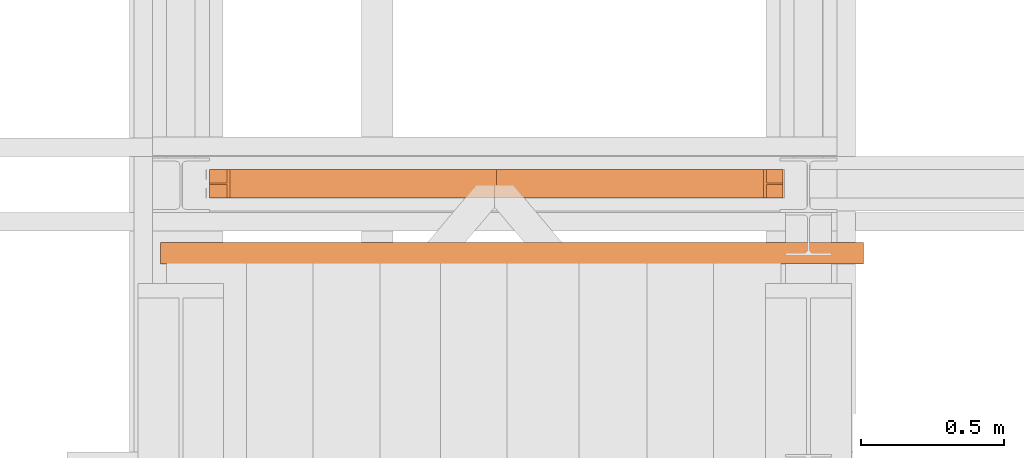
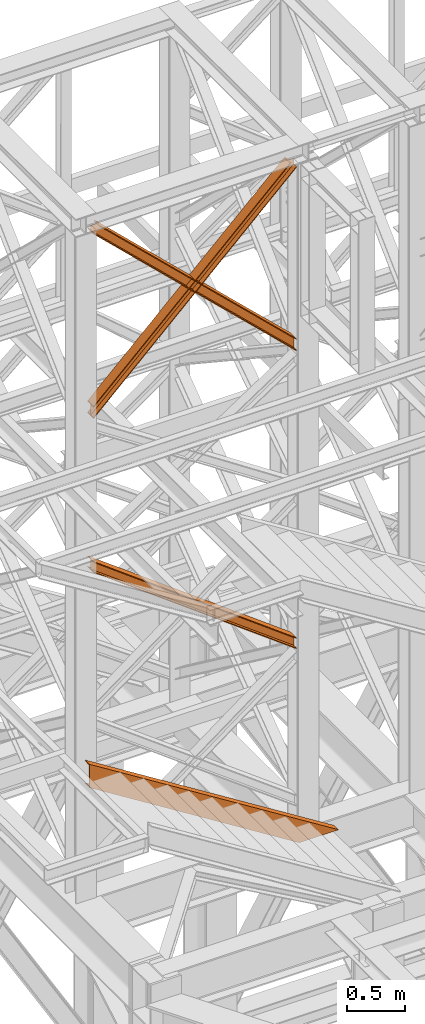
# One storey, part 89 of 208: 4 proxies.
"""IFC2X3 building model written with IfcOpenShell, lengths in millimetres."""

from ifc_helpers import new_model, entity, si_unit, converted_unit, frame, origin, origin_with_axes, place, context, subcontext, project, spatial, faceted_brep, element, save


model = new_model("IFC2X3")

# Units and contexts
model_context = context("Model", 3, precision=1e-05, world=origin())
plan_context = context("Plan", 3, precision=1e-05, world=origin())
body_context = subcontext(model_context, "Body", "Model", "MODEL_VIEW")
ifc_project = project(units=[si_unit("LENGTHUNIT", "METRE", prefix="MILLI"), converted_unit("PLANEANGLEUNIT", "DEGREE", entity("IfcPlaneAngleMeasure", 0.0174532925199433), si_unit("PLANEANGLEUNIT", "RADIAN"), dimensions=[0, 0, 0, 0, 0, 0, 0]), si_unit("AREAUNIT", "SQUARE_METRE"), si_unit("VOLUMEUNIT", "CUBIC_METRE")], contexts=[model_context, plan_context])

# Building, storey
building_placement = place(None, origin())
building = spatial("IfcBuilding", under=ifc_project, at=building_placement, CompositionType="COMPLEX")
storey_placement = place(building_placement, origin_with_axes())
storey = spatial("IfcBuildingStorey", under=building, at=storey_placement, Name="Geschoss", CompositionType="ELEMENT")

# Proxies
proxy_1_placement = place(storey_placement, frame((-3206.582751348882, -16012.93371125112, 7147.394064575148), z_axis=(0.0, 0.0, 1.0), x_axis=(1.0, 0.0, 0.0)))
element("IfcBuildingElementProxy", 1, at=proxy_1_placement, inside=storey, context=body_context, shape_type="Brep", body=[
    faceted_brep([(0.01000000000021828, 100.0229386519495, 1501.524522111415), (2010.009987483026, 100.1855729074941, 0.02100513656296243), (2010.009987483026, 100.1844946360343, 9.82075546136366), (0.01000000000021828, 100.0218603804897, 1511.324272436212), (0.01000000000021828, 0.0229392575147358, 1501.513516974852), (2010.009987483026, 0.185573513057534, 0.01000000000021828), (2010.009987483026, 100.1855729074941, 0.02100513656296243), (0.01000000000021828, 100.0229386519495, 1501.524522111415), (0.01000000000067303, 0.02186098605307052, 1511.313267299649), (2010.009987483026, 0.1844952415976877, 9.809750324800916), (2010.009987483026, 0.185573513057534, 0.01000000000021828), (0.01000000000021828, 0.0229392575147358, 1501.513516974852), (0.01000000000021828, 47.52186069841082, 1511.318494739518), (2010.009987483026, 47.68449495395362, 9.814977764666764), (2010.009987483026, 0.1844952415976877, 9.809750324800916), (0.01000000000067303, 0.02186098605307052, 1511.313267299649), (0.01000000000067303, 47.51107798381236, 1609.315997987507), (2010.009987483026, 47.67371223935879, 107.8124810126556), (2010.009987483026, 47.68449495395362, 9.814977764666764), (0.01000000000021828, 47.52186069841082, 1511.318494739518), (0.01000000000067303, 0.01107827145824558, 1609.310770547641), (2010.009987483026, 0.1737125270010438, 107.8072535727861), (2010.009987483026, 47.67371223935879, 107.8124810126556), (0.01000000000067303, 47.51107798381236, 1609.315997987507), (0.01000000000067303, 0.00999999999839929, 1619.110520872438), (2010.009987483026, 0.1726342555430165, 117.6070038975868), (2010.009987483026, 0.1737125270010438, 107.8072535727861), (0.01000000000067303, 0.01107827145824558, 1609.310770547641), (0.01000000000021828, 100.0099993944332, 1619.121526009001), (2010.009987483026, 100.172633649976, 117.6180090341495), (2010.009987483026, 0.1726342555430165, 117.6070038975868), (0.01000000000067303, 0.00999999999839929, 1619.110520872438), (0.01000000000021828, 100.011077665893, 1609.321775684197), (2010.009987483026, 100.1737119214358, 107.8182587093452), (2010.009987483026, 100.172633649976, 117.6180090341495), (0.01000000000021828, 100.0099993944332, 1619.121526009001), (0.01000000000021828, 52.51107795353528, 1609.316548244331), (2010.009987483026, 52.67371220908171, 107.8130312694793), (2010.009987483026, 100.1737119214358, 107.8182587093452), (0.01000000000021828, 100.011077665893, 1609.321775684197), (0.01000000000067303, 52.52186066813192, 1511.319044996339), (2010.009987483026, 52.68449492367836, 9.815528021497812), (2010.009987483026, 52.67371220908171, 107.8130312694793), (0.01000000000021828, 52.51107795353528, 1609.316548244331), (0.01000000000021828, 100.0218603804897, 1511.324272436212), (2010.009987483026, 100.1844946360343, 9.82075546136366), (2010.009987483026, 52.68449492367836, 9.815528021497812), (0.01000000000067303, 52.52186066813192, 1511.319044996339), (2010.009987483026, 100.1855729074941, 0.02100513656296243), (2010.009987483026, 0.185573513057534, 0.01000000000021828), (2010.009987483026, 0.1844952415976877, 9.809750324800916), (2010.009987483026, 47.68449495395362, 9.814977764666764), (2010.009987483026, 47.67371223935879, 107.8124810126556), (2010.009987483026, 0.1737125270010438, 107.8072535727861), (2010.009987483026, 0.1726342555430165, 117.6070038975868), (2010.009987483026, 100.172633649976, 117.6180090341495), (2010.009987483026, 100.1737119214358, 107.8182587093452), (2010.009987483026, 52.67371220908171, 107.8130312694793), (2010.009987483026, 52.68449492367836, 9.815528021497812), (2010.009987483026, 100.1844946360343, 9.82075546136366), (0.01000000000021828, 100.0218603804897, 1511.324272436212), (0.01000000000067303, 52.52186066813192, 1511.319044996339), (0.01000000000021828, 52.51107795353528, 1609.316548244331), (0.01000000000021828, 100.011077665893, 1609.321775684197), (0.01000000000021828, 100.0099993944332, 1619.121526009001), (0.01000000000067303, 0.00999999999839929, 1619.110520872438), (0.01000000000067303, 0.01107827145824558, 1609.310770547641), (0.01000000000067303, 47.51107798381236, 1609.315997987507), (0.01000000000021828, 47.52186069841082, 1511.318494739518), (0.01000000000067303, 0.02186098605307052, 1511.313267299649), (0.01000000000021828, 0.0229392575147358, 1501.513516974852), (0.01000000000021828, 100.0229386519495, 1501.524522111415)], [[[0, 1, 2, 3]], [[4, 5, 6, 7]], [[8, 9, 10, 11]], [[12, 13, 14, 15]], [[16, 17, 18, 19]], [[20, 21, 22, 23]], [[24, 25, 26, 27]], [[28, 29, 30, 31]], [[32, 33, 34, 35]], [[36, 37, 38, 39]], [[40, 41, 42, 43]], [[44, 45, 46, 47]], [[48, 49, 50, 51, 52, 53, 54, 55, 56, 57, 58, 59]], [[60, 61, 62, 63, 64, 65, 66, 67, 68, 69, 70, 71]]], orient=[[False], [False], [False], [False], [False], [False], [False], [False], [False], [False], [False], [False], [False], [False]]),
])
proxy_2_placement = place(storey_placement, frame((-3206.582751348882, -16013.12009277258, 10257.71351554296), z_axis=(0.0, 0.0, 1.0), x_axis=(1.0, 0.0, 0.0)))
element("IfcBuildingElementProxy", 2, at=proxy_2_placement, inside=storey, context=body_context, shape_type="Brep", body=[
    faceted_brep([(0.009999999999763531, 100.0212045496901, 119.6472293306997), (1953.293711336966, 100.1463438185765, 1992.286543150845), (1941.949222048048, 100.1466350609662, 1992.286543150845), (0.01000000000021828, 100.0222231921616, 130.5233411127829), (0.01000000000021828, 100.0222231921616, 130.5233411127829), (1941.949222048048, 100.1466350609662, 1992.286543150845), (1941.937468339427, 0.1466348943758931, 1992.286543150842), (0.01000000000067303, 0.02222377857833635, 130.5346095510231), (0.01000000000067303, 0.02222377857833635, 130.5346095510231), (1941.937468339427, 0.1466348943758931, 1992.286543150842), (1953.281957628329, 0.1463436519825336, 1992.286543150842), (0.01000000000067303, 0.02120513611225761, 119.6584977689327), (0.01000000000067303, 0.02120513611225761, 119.6584977689327), (1953.281957628329, 0.1463436519825336, 1992.286543150842), (1953.287540639933, 47.64634373111403, 1992.286543150845), (0.01000000000067303, 47.52120485756132, 119.6531452607651), (0.01000000000067303, 47.52120485756132, 119.6531452607651), (1953.287540639933, 47.64634373111403, 1992.286543150845), (2010.009987483026, 47.64488761591929, 1992.286543150845), (2010.009987483026, 47.63979748861675, 1937.905972056111), (0.01000000000021828, 47.51101837541864, 10.89202766673589), (0.01000000000021828, 47.51101837541864, 10.89202766673589), (2010.009987483026, 47.63979748861675, 1937.905972056111), (2010.009987483026, 0.1397977671695116, 1937.911324564264), (0.01000000000067303, 0.011018653971405, 10.89738017488162), (0.01000000000067303, 0.011018653971405, 10.89738017488162), (2010.009987483026, 0.1397977671695116, 1937.911324564264), (2010.009987483026, 0.138779739916572, 1927.035210352397), (0.01000000000067303, 0.01000000000021828, 0.02126843821861257), (0.01000000000067303, 0.01000000000021828, 0.02126843821861257), (2010.009987483026, 0.138779739916572, 1927.035210352397), (2010.009987483026, 100.1387791534962, 1927.023941914182), (0.01000000000112777, 100.0099994135762, 0.01000000000021828), (0.01000000000112777, 100.0099994135762, 0.01000000000021828), (2010.009987483026, 100.1387791534962, 1927.023941914182), (2010.009987483026, 100.1397971807455, 1937.900056126053), (0.01000000000067303, 100.0110180675511, 10.88611173667414), (0.01000000000067303, 100.0110180675511, 10.88611173667414), (2010.009987483026, 100.1397971807455, 1937.900056126053), (2010.009987483026, 52.63979745929828, 1937.905408634202), (0.01000000000067303, 52.51101834609835, 10.89146424482351), (0.01000000000067303, 52.51101834609835, 10.89146424482351), (2010.009987483026, 52.63979745929828, 1937.905408634202), (2010.009993572537, 52.64488763917871, 1992.286543150845), (1953.288128325361, 52.64634373944318, 1992.286543150845), (0.01000000000021828, 52.52120482823921, 119.65258183886), (0.01000000000021828, 52.52120482823921, 119.65258183886), (1953.288128325361, 52.64634373944318, 1992.286543150845), (1953.293711336966, 100.1463438185765, 1992.286543150845), (0.009999999999763531, 100.0212045496901, 119.6472293306997), (1953.293711336966, 100.1463438185765, 1992.286543150845), (1953.288128325361, 52.64634373944318, 1992.286543150845), (2010.009993572537, 52.64488763917871, 1992.286543150845), (2010.009987483026, 47.64488761591929, 1992.286543150845), (1953.287540639933, 47.64634373111403, 1992.286543150845), (1953.281957628329, 0.1463436519825336, 1992.286543150842), (1941.937468339427, 0.1466348943758931, 1992.286543150842), (1941.949222048048, 100.1466350609662, 1992.286543150845), (2010.009987483026, 47.64488761591929, 1992.286543150845), (2010.009993572537, 52.64488763917871, 1992.286543150845), (2010.009987483026, 52.63979745929828, 1937.905408634202), (2010.009987483026, 100.1397971807455, 1937.900056126053), (2010.009987483026, 100.1387791534962, 1927.023941914182), (2010.009987483026, 0.138779739916572, 1927.035210352397), (2010.009987483026, 0.1397977671695116, 1937.911324564264), (2010.009987483026, 47.63979748861675, 1937.905972056111), (0.01000000000021828, 100.0222231921616, 130.5233411127829), (0.01000000000067303, 0.02222377857833635, 130.5346095510231), (0.01000000000067303, 0.02120513611225761, 119.6584977689327), (0.01000000000067303, 47.52120485756132, 119.6531452607651), (0.01000000000021828, 47.51101837541864, 10.89202766673589), (0.01000000000067303, 0.011018653971405, 10.89738017488162), (0.01000000000067303, 0.01000000000021828, 0.02126843821861257), (0.01000000000112777, 100.0099994135762, 0.01000000000021828), (0.01000000000067303, 100.0110180675511, 10.88611173667414), (0.01000000000067303, 52.51101834609835, 10.89146424482351), (0.01000000000021828, 52.52120482823921, 119.65258183886), (0.009999999999763531, 100.0212045496901, 119.6472293306997)], [[[0, 1, 2, 3]], [[4, 5, 6, 7]], [[8, 9, 10, 11]], [[12, 13, 14, 15]], [[16, 17, 18, 19, 20]], [[21, 22, 23, 24]], [[25, 26, 27, 28]], [[29, 30, 31, 32]], [[33, 34, 35, 36]], [[37, 38, 39, 40]], [[41, 42, 43, 44, 45]], [[46, 47, 48, 49]], [[50, 51, 52, 53, 54, 55, 56, 57]], [[58, 59, 60, 61, 62, 63, 64, 65]], [[66, 67, 68, 69, 70, 71, 72, 73, 74, 75, 76, 77]]], orient=[[False], [False], [False], [False], [False], [False], [False], [False], [False], [False], [False], [False], [False], [False], [False]]),
])
proxy_3_placement = place(storey_placement, frame((-3206.582751348881, -16013.10032139283, 10261.20680675583), z_axis=(0.0, 0.0, 1.0), x_axis=(1.0, 0.0, 0.0)))
element("IfcBuildingElementProxy", 3, at=proxy_3_placement, inside=storey, context=body_context, shape_type="Brep", body=[
    faceted_brep([(2010.009987483025, 100.0219376352106, 130.5376928144524), (72.13175719670971, 100.1248673996142, 1988.793251937981), (60.78837531823774, 100.1244756427459, 1988.793251937985), (2010.009987483025, 100.0209427866557, 119.6603850577285), (2010.009987483025, 0.02193825012000161, 130.5496157990219), (72.14419105820798, 0.1248673541031167, 1988.793251937981), (72.13175719670971, 100.1248673996142, 1988.793251937981), (2010.009987483025, 100.0219376352106, 130.5376928144524), (2010.009987483025, 0.02094340156691033, 119.6723080422798), (60.8008091797451, 0.1244755972311396, 1988.793251937981), (72.14419105820798, 0.1248673541031167, 1988.793251937981), (2010.009987483025, 0.02193825012000161, 130.5496157990219), (2010.009987483025, 47.52094310948451, 119.6666446246109), (60.79490309553421, 47.62447561884983, 1988.793251937981), (60.8008091797451, 0.1244755972311396, 1988.793251937981), (2010.009987483025, 0.02094340156691033, 119.6723080422798), (2010.009987483025, 47.51099456772136, 10.89356727918312), (0.009999999999763531, 47.61776178021319, 1938.307550640491), (0.009999999999763531, 47.62237652174554, 1988.793251937981), (60.79490309553421, 47.62447561884983, 1988.793251937981), (2010.009987483025, 47.52094310948451, 119.6666446246109), (2010.009987483025, 0.01099485980739701, 10.899230696823), (0.009999999999763531, 0.1177620722974098, 1938.313214058149), (0.009999999999763531, 47.61776178021319, 1938.307550640491), (2010.009987483025, 47.51099456772136, 10.89356727918312), (2010.009987483025, 0.01000000000021828, 0.02192298452973773), (0.009999999999763531, 0.1167678252622864, 1927.43590392548), (0.009999999999763531, 0.1177620722974098, 1938.313214058149), (2010.009987483025, 0.01099485980739701, 10.899230696823), (2010.009987483025, 100.0099993850836, 0.01000000000021828), (0.009999999999763531, 100.1167672103493, 1927.42398094095), (0.009999999999763531, 0.1167678252622864, 1927.43590392548), (2010.009987483025, 0.01000000000021828, 0.02192298452973773), (2010.009987483025, 100.0109942448944, 10.88730771230075), (0.009999999999763531, 100.117761457379, 1938.301291073616), (0.009999999999763531, 100.1167672103493, 1927.42398094095), (2010.009987483025, 100.0099993850836, 0.01000000000021828), (2010.009987483025, 52.51099453697134, 10.89297112994063), (0.009999999999763531, 52.61776174946681, 1938.306954491263), (0.009999999999763531, 100.117761457379, 1938.301291073616), (2010.009987483025, 100.0109942448944, 10.88730771230075), (2010.009987483025, 52.52094307873631, 119.6660484753793), (60.79428140245909, 52.62447562112538, 1988.793251937981), (0.009999999999763531, 52.62237654549062, 1988.793251937981), (0.009999999999763531, 52.61776174946681, 1938.306954491263), (2010.009987483025, 52.51099453697134, 10.89297112994063), (2010.009987483025, 100.0209427866557, 119.6603850577285), (60.78837531823774, 100.1244756427459, 1988.793251937985), (60.79428140245909, 52.62447562112538, 1988.793251937981), (2010.009987483025, 52.52094307873631, 119.6660484753793), (72.13175719670971, 100.1248673996142, 1988.793251937981), (72.14419105820798, 0.1248673541031167, 1988.793251937981), (60.8008091797451, 0.1244755972311396, 1988.793251937981), (60.79490309553421, 47.62447561884983, 1988.793251937981), (0.009999999999763531, 47.62237652174554, 1988.793251937981), (0.009999999999763531, 52.62237654549062, 1988.793251937981), (60.79428140245909, 52.62447562112538, 1988.793251937981), (60.78837531823774, 100.1244756427459, 1988.793251937985), (0.009999999999763531, 47.62237652174554, 1988.793251937981), (0.009999999999763531, 47.61776178021319, 1938.307550640491), (0.009999999999763531, 0.1177620722974098, 1938.313214058149), (0.009999999999763531, 0.1167678252622864, 1927.43590392548), (0.009999999999763531, 100.1167672103493, 1927.42398094095), (0.009999999999763531, 100.117761457379, 1938.301291073616), (0.009999999999763531, 52.61776174946681, 1938.306954491263), (0.009999999999763531, 52.62237654549062, 1988.793251937981), (2010.009987483025, 100.0209427866557, 119.6603850577285), (2010.009987483025, 52.52094307873631, 119.6660484753793), (2010.009987483025, 52.51099453697134, 10.89297112994063), (2010.009987483025, 100.0109942448944, 10.88730771230075), (2010.009987483025, 100.0099993850836, 0.01000000000021828), (2010.009987483025, 0.01000000000021828, 0.02192298452973773), (2010.009987483025, 0.01099485980739701, 10.899230696823), (2010.009987483025, 47.51099456772136, 10.89356727918312), (2010.009987483025, 47.52094310948451, 119.6666446246109), (2010.009987483025, 0.02094340156691033, 119.6723080422798), (2010.009987483025, 0.02193825012000161, 130.5496157990219), (2010.009987483025, 100.0219376352106, 130.5376928144524)], [[[0, 1, 2, 3]], [[4, 5, 6, 7]], [[8, 9, 10, 11]], [[12, 13, 14, 15]], [[16, 17, 18, 19, 20]], [[21, 22, 23, 24]], [[25, 26, 27, 28]], [[29, 30, 31, 32]], [[33, 34, 35, 36]], [[37, 38, 39, 40]], [[41, 42, 43, 44, 45]], [[46, 47, 48, 49]], [[50, 51, 52, 53, 54, 55, 56, 57]], [[58, 59, 60, 61, 62, 63, 64, 65]], [[66, 67, 68, 69, 70, 71, 72, 73, 74, 75, 76, 77]]], orient=[[False], [False], [False], [False], [False], [False], [False], [False], [False], [False], [False], [False], [False], [False], [False]]),
])
proxy_4_placement = place(storey_placement, frame((-3377.982231929546, -16243.56428126889, 5299.235995667714), z_axis=(0.0, 0.0, 1.0), x_axis=(1.0, 0.0, 0.0)))
element("IfcBuildingElementProxy", 4, at=proxy_4_placement, inside=storey, context=body_context, shape_type="Brep", body=[
    faceted_brep([(0.01000000000021828, 0.01000000000021828, 1301.03525473074), (0.01000000000021828, 0.01000000000021828, 1546.598640795312), (2463.776225798725, 0.01000000000021828, 0.01000000000294676), (2072.585730200912, 0.01000000000021828, 0.01000000000294676), (0.01000000000021828, 0.01000000000021828, 1546.598640795312), (0.01000000000021828, 75.01000111758731, 1546.598640795312), (2463.776225798725, 75.01000111758731, 0.01000000000294676), (2463.776225798725, 0.01000000000021828, 0.01000000000294676), (0.01000000000021828, 75.01000111758731, 1546.598640795312), (0.01000000000021828, 75.01000111758731, 1542.963282509619), (2457.984981296655, 75.01000111758731, 0.01000000000294676), (2463.776225798725, 75.01000111758731, 0.01000000000294676), (0.01000000000021828, 75.01000111758731, 1542.963282509619), (0.01000000000021828, 73.89400100171588, 1537.56333977627), (2449.382696127385, 73.89400100171588, 0.01000000000203727), (2457.984981296655, 75.01000111758731, 0.01000000000294676), (0.01000000000021828, 73.89400100171588, 1537.56333977627), (0.01000000000021828, 69.48847269475482, 1535.619839744783), (2446.28663709067, 69.48847269475482, 0.01000000000385626), (2449.382696127385, 73.89400100171588, 0.01000000000203727), (0.01000000000021828, 69.48847269475482, 1535.619839744783), (0.01000000000021828, 19.09293180167697, 1530.66971995284), (2438.400934561024, 19.09293180167697, 0.01000000000294676), (2446.28663709067, 69.48847269475482, 0.01000000000385626), (0.01000000000021828, 19.09293180167697, 1530.66971995284), (0.01000000000021828, 13.35380079060815, 1528.711080065991), (2435.280757240156, 13.35380079060815, 0.01000000000021828), (2438.400934561024, 19.09293180167697, 0.01000000000294676), (0.01000000000021828, 13.35380079060815, 1528.711080065991), (0.01000000000021828, 9.50015002697728, 1523.455656628751), (2426.908696030466, 9.50015002697728, 0.01000000000294676), (2435.280757240156, 13.35380079060815, 0.01000000000021828), (0.01000000000021828, 9.50015002697728, 1523.455656628751), (0.01000000000021828, 8.510000461936215, 1516.594795610196), (2415.979120310369, 8.510000461936215, 0.01000000000294676), (2426.908696030466, 9.50015002697728, 0.01000000000294676), (0.01000000000021828, 8.510000461936215, 1516.594795610196), (0.01000000000021828, 8.510000461936215, 1331.039099915858), (2120.382835689267, 8.510000461936215, 0.01000000000294676), (2415.979120310369, 8.510000461936215, 0.01000000000294676), (0.01000000000021828, 8.510000461936215, 1331.039099915858), (0.01000000000021828, 9.50015002697728, 1324.178238897302), (2109.453259969166, 9.50015002697728, 0.01000000000294676), (2120.382835689267, 8.510000461936215, 0.01000000000294676), (0.01000000000021828, 9.50015002697728, 1324.178238897302), (0.01000000000021828, 13.35380079060815, 1318.922815460061), (2101.08119875948, 13.35380079060815, 0.01000000000294676), (2109.453259969166, 9.50015002697728, 0.01000000000294676), (0.01000000000021828, 13.35380079060815, 1318.922815460061), (0.01000000000021828, 19.09293180167697, 1316.964175573211), (2097.96102143861, 19.09293180167697, 0.01000000000385626), (2101.08119875948, 13.35380079060815, 0.01000000000294676), (0.01000000000021828, 19.09293180167697, 1316.964175573211), (0.01000000000021828, 69.48847269475482, 1312.014055781273), (2090.075318908967, 69.48847269475482, 0.01000000000203727), (2097.96102143861, 19.09293180167697, 0.01000000000385626), (0.01000000000021828, 69.48847269475482, 1312.014055781273), (0.01000000000021828, 73.89400100171588, 1310.070555749785), (2086.979259872251, 73.89400100171588, 0.01000000000476575), (2090.075318908967, 69.48847269475482, 0.01000000000203727), (0.01000000000021828, 73.89400100171588, 1310.070555749785), (0.01000000000021828, 75.01000111758731, 1304.670613016434), (2078.376974702981, 75.01000111758731, 0.01000000000294676), (2086.979259872251, 73.89400100171588, 0.01000000000476575), (0.01000000000021828, 75.01000111758731, 1304.670613016434), (0.01000000000021828, 75.01000111758731, 1301.03525473074), (2072.585730200911, 75.01000111758731, 0.01000000000294676), (2078.376974702981, 75.01000111758731, 0.01000000000294676), (0.01000000000021828, 75.01000111758731, 1301.03525473074), (0.01000000000021828, 0.01000000000021828, 1301.03525473074), (2072.585730200912, 0.01000000000021828, 0.01000000000294676), (2072.585730200911, 75.01000111758731, 0.01000000000294676), (0.01000000000021828, 0.01000000000021828, 1301.03525473074), (0.01000000000021828, 75.01000111758731, 1301.03525473074), (0.01000000000021828, 75.01000111758731, 1304.670613016434), (0.01000000000021828, 73.89400100171588, 1310.070555749785), (0.01000000000021828, 69.48847269475482, 1312.014055781273), (0.01000000000021828, 19.09293180167697, 1316.964175573211), (0.01000000000021828, 13.35380079060815, 1318.922815460061), (0.01000000000021828, 9.50015002697728, 1324.178238897302), (0.01000000000021828, 8.510000461936215, 1331.039099915858), (0.01000000000021828, 8.510000461936215, 1516.594795610196), (0.01000000000021828, 9.50015002697728, 1523.455656628751), (0.01000000000021828, 13.35380079060815, 1528.711080065991), (0.01000000000021828, 19.09293180167697, 1530.66971995284), (0.01000000000021828, 69.48847269475482, 1535.619839744783), (0.01000000000021828, 73.89400100171588, 1537.56333977627), (0.01000000000021828, 75.01000111758731, 1542.963282509619), (0.01000000000021828, 75.01000111758731, 1546.598640795312), (0.01000000000021828, 0.01000000000021828, 1546.598640795312), (2072.585730200912, 0.01000000000021828, 0.01000000000294676), (2463.776225798725, 0.01000000000021828, 0.01000000000294676), (2463.776225798725, 75.01000111758731, 0.01000000000294676), (2457.984981296655, 75.01000111758731, 0.01000000000294676), (2449.382696127385, 73.89400100171588, 0.01000000000203727), (2446.28663709067, 69.48847269475482, 0.01000000000385626), (2438.400934561024, 19.09293180167697, 0.01000000000294676), (2435.280757240156, 13.35380079060815, 0.01000000000021828), (2426.908696030466, 9.50015002697728, 0.01000000000294676), (2415.979120310369, 8.510000461936215, 0.01000000000294676), (2120.382835689267, 8.510000461936215, 0.01000000000294676), (2109.453259969166, 9.50015002697728, 0.01000000000294676), (2101.08119875948, 13.35380079060815, 0.01000000000294676), (2097.96102143861, 19.09293180167697, 0.01000000000385626), (2090.075318908967, 69.48847269475482, 0.01000000000203727), (2086.979259872251, 73.89400100171588, 0.01000000000476575), (2078.376974702981, 75.01000111758731, 0.01000000000294676), (2072.585730200911, 75.01000111758731, 0.01000000000294676)], [[[0, 1, 2, 3]], [[4, 5, 6, 7]], [[8, 9, 10, 11]], [[12, 13, 14, 15]], [[16, 17, 18, 19]], [[20, 21, 22, 23]], [[24, 25, 26, 27]], [[28, 29, 30, 31]], [[32, 33, 34, 35]], [[36, 37, 38, 39]], [[40, 41, 42, 43]], [[44, 45, 46, 47]], [[48, 49, 50, 51]], [[52, 53, 54, 55]], [[56, 57, 58, 59]], [[60, 61, 62, 63]], [[64, 65, 66, 67]], [[68, 69, 70, 71]], [[72, 73, 74, 75, 76, 77, 78, 79, 80, 81, 82, 83, 84, 85, 86, 87, 88, 89]], [[90, 91, 92, 93, 94, 95, 96, 97, 98, 99, 100, 101, 102, 103, 104, 105, 106, 107]]], orient=[[False], [False], [False], [False], [False], [False], [False], [False], [False], [False], [False], [False], [False], [False], [False], [False], [False], [False], [False], [False]]),
])

save(model, "model.ifc")
